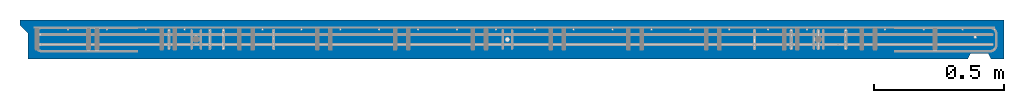
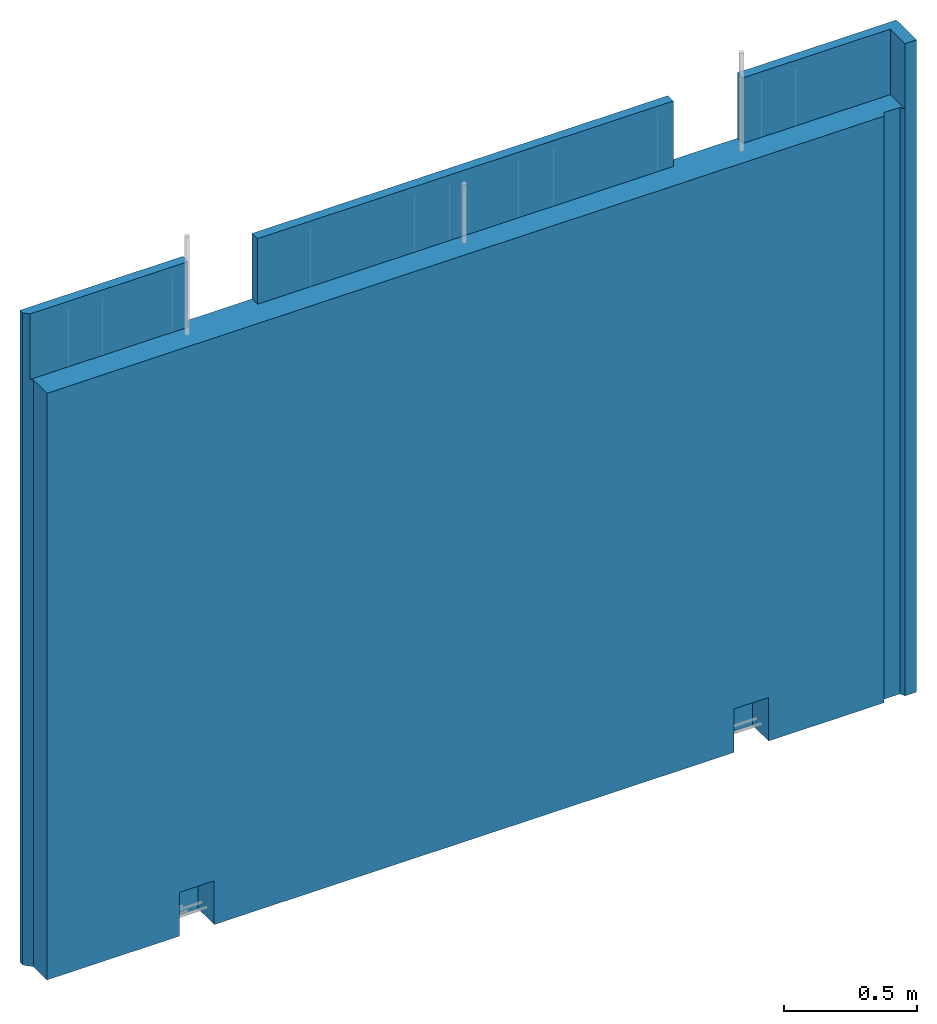
# One storey, part 9 of 9: 1 wall, 1 element without a shape of its own.
"""IFC2X3 building model written with IfcOpenShell, lengths in millimetres."""

from ifc_helpers import new_model, si_unit, frame, origin_with_axes, place, context, subcontext, project, spatial, faceted_brep, material, type_object, element, aggregate, save


model = new_model("IFC2X3")

# Units and contexts
model_context = context("Model", 3, precision=1e-05, world=origin_with_axes())
body_context = subcontext(model_context, "Body", "Model", "MODEL_VIEW")
ifc_project = project(units=[si_unit("LENGTHUNIT", "METRE", prefix="MILLI"), si_unit("AREAUNIT", "SQUARE_METRE"), si_unit("VOLUMEUNIT", "CUBIC_METRE"), si_unit("MASSUNIT", "GRAM", prefix="KILO"), si_unit("TIMEUNIT", "SECOND"), si_unit("PLANEANGLEUNIT", "RADIAN"), si_unit("SOLIDANGLEUNIT", "STERADIAN"), si_unit("THERMODYNAMICTEMPERATUREUNIT", "DEGREE_CELSIUS"), si_unit("LUMINOUSINTENSITYUNIT", "LUMEN")], contexts=[model_context])

# Site, building, storey
site_placement = place(None, origin_with_axes())
site = spatial("IfcSite", under=ifc_project, at=site_placement, CompositionType="ELEMENT")
building_placement = place(site_placement, origin_with_axes())
building = spatial("IfcBuilding", under=site, at=building_placement, Name="1", CompositionType="ELEMENT")
storey_placement = place(building_placement, origin_with_axes())
storey = spatial("IfcBuildingStorey", under=building, at=storey_placement, Name="1. kerros", CompositionType="ELEMENT", Elevation=0.0)

# Assembly, wall
assembly_placement = place(storey_placement, origin_with_axes())
assembly = element("IfcElementAssembly", 1, at=assembly_placement, inside=storey, AssemblyPlace="NOTDEFINED", PredefinedType="REINFORCEMENT_UNIT")
ifc_material = material(Name="CONCRETE/C30/37")
wall_type = type_object("IfcWallType", Name="2985X150", PredefinedType="NOTDEFINED")
wall_placement = place(assembly_placement, frame((35970.0022627602, 7575.00033187657, 1492.49992151562), z_axis=(0.0, 0.0, 1.0), x_axis=(0.999999999544916, -3.01690000135232e-05, 0.0)))
wall = element("IfcWall", 2, at=wall_placement, type_object=wall_type, material=ifc_material, ObjectType="2985X150", context=body_context, shape_type="Brep", body=[
    faceted_brep([(2805.0823305525, 74.9999999999991, 1492.49999999869), (2805.0835373125, 34.9999998308758, 1492.49999998225), (2805.08353731249, 34.9999998308758, 1192.49999997631), (2805.08233055249, 74.9999999999991, 1192.49999999791), (3105.08353744903, 34.9999998308749, 1192.49999997631), (3105.08233068902, 75.0, 1192.49999999791), (3105.08233068902, 74.9999999999991, 1492.49999999632), (3105.08353744903, 34.9999998308749, 1492.49999998035), (20.0000001430089, 34.9999998308758, 1492.49999999987), (20.0000001430089, 34.9999998308758, 1192.49999997631), (705.083536356811, 34.9999998308749, 1192.49999997631), (705.083536356819, 34.9999998308749, 1492.49999999554), (1005.08232973334, 74.9999999999991, 1492.49999999632), (1005.08232973334, 74.9999999999982, 1192.49999999791), (1005.08353649334, 34.9999998308758, 1192.49999997631), (1005.08353649334, 34.9999998308758, 1492.49999999364), (705.082329596808, 74.9999999999982, 1192.49999999791), (705.082329596815, 74.9999999999991, 1492.5), (0.0, 74.9999999999991, 1492.5), (-7.27595761418343e-12, 54.9999999999045, 1492.5), (604.079324010228, -74.982680446773, -1292.54627628753), (604.079426850221, 45.0173195531834, -1342.54627644571), (754.079426868993, 45.0171910031831, -1342.54627644571), (754.079324028993, -74.9828089967732, -1292.54627628753), (604.079426850221, 45.0173195531834, -1492.54627628753), (604.079324010228, -75.0000000000009, -1492.5), (754.079426868993, 45.0171910031831, -1492.54627628753), (754.079324028993, -75.0, -1492.5), (3004.07919795173, -74.9547929493847, -1293.32355708434), (3004.07930079172, 45.0452070505726, -1343.32355724257), (3154.07930080994, 45.0450785005714, -1343.32355724257), (3154.07919796995, -74.9549214993849, -1293.32355708434), (3004.07930079172, 45.0452070505726, -1492.51090734732), (3004.07919795173, -75.0, -1492.5), (3154.07930080994, 45.0450785005714, -1492.51090734813), (3154.07919796995, -75.0, -1492.5), (3664.40125343294, -54.9932071461599, 1192.49999997631), (3664.40125343294, -54.9932071461599, -1492.49999999915), (3734.40125343294, -54.9932071461608, -1492.49999999915), (3734.40125343294, -54.9932071461608, 1192.49999997631), (3654.40125343293, -75.0000001650615, 1192.49999997631), (3654.40125343294, -75.0000000000009, -1492.5), (3105.08685603902, -75.0000001402495, 1192.49999997631), (2805.08685590249, -75.000000126699, 1192.49999997631), (1005.08685508334, -75.0000000453983, 1192.49999997631), (705.086854946807, -75.0000000318478, 1192.49999997631), (29.9999999739739, -75.0000000013551, 1192.49999997631), (29.9999999739739, -75.0000000000009, -1492.5), (29.9999999739739, 24.9999999999054, 1192.49999997631), (29.9999999739739, 24.9999999999054, -1492.5), (-7.27595761418343e-12, 54.9999999999045, -1492.5), (0.0, 74.9999999999991, -1492.5), (3794.4033090715, -75.0, 1492.5), (3794.4033090715, -75.0, -1492.5), (3794.4033090715, 74.9999999999991, -1492.5), (3794.4033090715, 74.9999999999991, 1492.5), (3744.4033090148, 34.9999998308749, 1492.49999997631), (3744.4033090148, -75.0000000000009, 1492.5), (3744.4033090148, 34.9999998308749, 1192.49999997631), (3744.40125343294, -74.9932071458343, 1192.49999997631), (3744.40125343294, -75.0000000000009, -1492.5)], [[[0, 1, 2, 3]], [[3, 2, 4, 5]], [[6, 5, 4, 7]], [[8, 9, 10, 11]], [[12, 13, 14, 15]], [[16, 10, 14, 13]], [[17, 11, 10, 16]], [[18, 19, 8, 11, 17]], [[20, 21, 22, 23]], [[24, 21, 20, 25]], [[26, 22, 21, 24]], [[27, 23, 22, 26]], [[28, 29, 30, 31]], [[32, 29, 28, 33]], [[34, 30, 29, 32]], [[35, 31, 30, 34]], [[36, 37, 38, 39]], [[40, 41, 37, 36]], [[42, 43, 44, 45, 46, 47, 25, 20, 23, 27, 33, 28, 31, 35, 41, 40]], [[48, 49, 47, 46]], [[9, 8, 19, 50, 49, 48]], [[18, 51, 50, 19]], [[52, 53, 54, 55]], [[56, 57, 52, 55, 6, 7]], [[58, 56, 7, 4]], [[56, 58, 59, 57]], [[53, 52, 57, 59, 60]], [[37, 41, 35, 34, 32, 33, 27, 26, 24, 25, 47, 49, 50, 51, 54, 53, 60, 38]], [[59, 39, 38, 60]], [[58, 4, 2, 14, 10, 9, 48, 46, 45, 44, 43, 42, 40, 36, 39, 59]], [[15, 14, 2, 1]], [[12, 15, 1, 0]], [[55, 54, 51, 18, 17, 16, 13, 12, 0, 3, 5, 6]]]),
])
aggregate(assembly, [wall])

save(model, "model.ifc")
